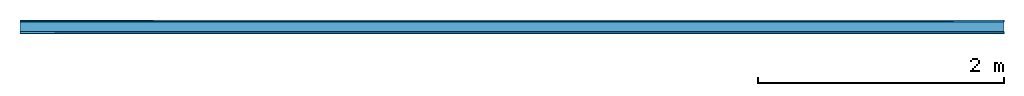
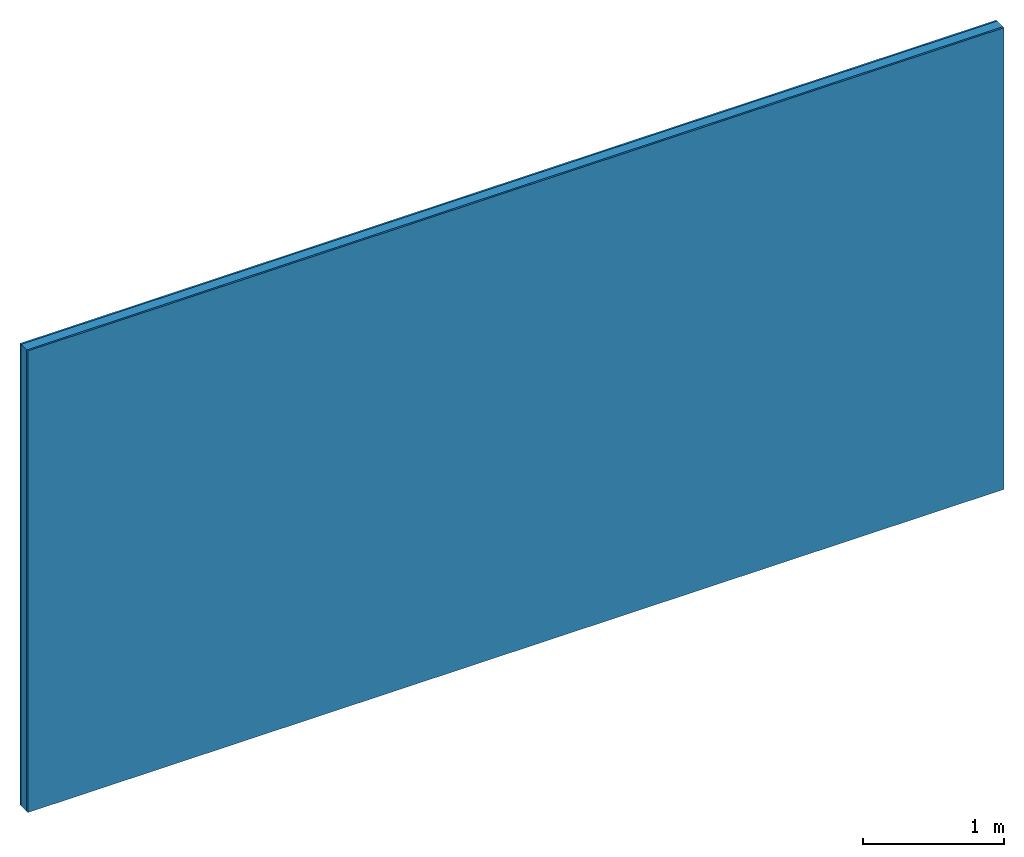
# One storey: 2 plates, 1 member, 1 element without a shape of its own.
"""IFC4 building model written with IfcOpenShell, lengths in metres."""

from ifc_helpers import new_model, si_unit, derived_unit, direction, frame, frame_2d, origin, origin_with_axes, place, context, project, spatial, rectangle, extrude, material, layer, layer_set, type_object, element, aggregate, save


model = new_model("IFC4")

# Units and contexts
plan_context = context("Plan", 3, precision=1e-05, world=origin(), true_north=direction((0.0, 1.0)))
model_context = context("Model", 3, precision=1e-05, world=origin(), true_north=direction((0.0, 1.0)))
ifc_project = project(units=[si_unit("LENGTHUNIT", "METRE"), derived_unit("SOUNDPRESSUREUNIT", [(si_unit("PRESSUREUNIT", "PASCAL", prefix="MICRO"), 0)]), si_unit("ENERGYUNIT", "JOULE", prefix="MEGA"), si_unit("MASSUNIT", "GRAM", prefix="KILO"), derived_unit("THERMALTRANSMITTANCEUNIT", [(si_unit("POWERUNIT", "WATT"), 1), (si_unit("AREAUNIT", "SQUARE_METRE"), -1), (si_unit("THERMODYNAMICTEMPERATUREUNIT", "KELVIN"), -1)]), derived_unit("AREADENSITYUNIT", [(si_unit("MASSUNIT", "GRAM", prefix="KILO"), 1), (si_unit("AREAUNIT", "SQUARE_METRE"), -1)]), derived_unit("USERDEFINED", [(si_unit("ENERGYUNIT", "JOULE", prefix="MEGA"), 1), (si_unit("AREAUNIT", "SQUARE_METRE"), -1)])], contexts=[plan_context, model_context])

# Site, building, storey
site = spatial("IfcSite", under=ifc_project)
building_placement = place(None, origin())
building = spatial("IfcBuilding", under=site, at=building_placement)
storey_placement = place(building_placement, origin())
storey = spatial("IfcBuildingStorey", under=building, at=storey_placement)

# Wall, member, plates
ifc_material_1 = material(Name="Glued joints")
ifc_layer_1 = layer(ifc_material_1, 0.0, Name="Surface")
ifc_material_2 = material(Category="03.007")
ifc_layer_2 = layer(ifc_material_2, 0.015, Name="1st layer")
ifc_material_3 = material(Name="of the art")
ifc_layer_3 = layer(ifc_material_3, 0.0, Name="Bond")
ifc_layer_4 = layer(None, 0.08, Name="Support")
ifc_layer_5 = layer(ifc_material_3, 0.0, Name="Bond")
ifc_layer_6 = layer(ifc_material_2, 0.015, Name="1st layer")
ifc_layer_7 = layer(ifc_material_1, 0.0, Name="Surface")
ifc_layer_set = layer_set([ifc_layer_1, ifc_layer_2, ifc_layer_3, ifc_layer_4, ifc_layer_5, ifc_layer_6, ifc_layer_7])
wall_type = type_object("IfcWallType", Name="C0109", PredefinedType="NOTDEFINED", material=ifc_layer_set)
wall_placement = place(None, frame((0.0, 0.0, 0.0), z_axis=(0.0, -1.0, 0.0), x_axis=(1.0, 0.0, 0.0)))
wall = element("IfcWall", 1, at=wall_placement, inside=storey, type_object=wall_type, material=ifc_layer_set, Name="Wall #1")
ifc_material_4 = material()
member_placement = place(wall_placement, origin())
member = element("IfcMember", 2, at=member_placement, material=ifc_material_4, Name="Support", context=plan_context, shape_type="SweptSolid", body=[
    extrude(rectangle(XDim=1.0, YDim=0.08, at=frame_2d((0.5, 0.04), x_axis=(1.0, 0.0))), frame((0.0, 4.0, 0.015), z_axis=(0.0, -1.0, 0.0), x_axis=(1.0, 0.0, 0.0)), (0.0, 0.0, 1.0), 4.0),
    extrude(rectangle(XDim=1.0, YDim=0.08, at=frame_2d((0.5, 0.04), x_axis=(1.0, 0.0))), frame((1.0, 4.0, 0.015), z_axis=(0.0, -1.0, 0.0), x_axis=(1.0, 0.0, 0.0)), (0.0, 0.0, 1.0), 4.0),
    extrude(rectangle(XDim=1.0, YDim=0.08, at=frame_2d((0.5, 0.04), x_axis=(1.0, 0.0))), frame((2.0, 4.0, 0.015), z_axis=(0.0, -1.0, 0.0), x_axis=(1.0, 0.0, 0.0)), (0.0, 0.0, 1.0), 4.0),
    extrude(rectangle(XDim=1.0, YDim=0.08, at=frame_2d((0.5, 0.04), x_axis=(1.0, 0.0))), frame((3.0, 4.0, 0.015), z_axis=(0.0, -1.0, 0.0), x_axis=(1.0, 0.0, 0.0)), (0.0, 0.0, 1.0), 4.0),
    extrude(rectangle(XDim=1.0, YDim=0.08, at=frame_2d((0.5, 0.04), x_axis=(1.0, 0.0))), frame((4.0, 4.0, 0.015), z_axis=(0.0, -1.0, 0.0), x_axis=(1.0, 0.0, 0.0)), (0.0, 0.0, 1.0), 4.0),
    extrude(rectangle(XDim=1.0, YDim=0.08, at=frame_2d((0.5, 0.04), x_axis=(1.0, 0.0))), frame((5.0, 4.0, 0.015), z_axis=(0.0, -1.0, 0.0), x_axis=(1.0, 0.0, 0.0)), (0.0, 0.0, 1.0), 4.0),
    extrude(rectangle(XDim=1.0, YDim=0.08, at=frame_2d((0.5, 0.04), x_axis=(1.0, 0.0))), frame((6.0, 4.0, 0.015), z_axis=(0.0, -1.0, 0.0), x_axis=(1.0, 0.0, 0.0)), (0.0, 0.0, 1.0), 4.0),
    extrude(rectangle(XDim=1.0, YDim=0.08, at=frame_2d((0.5, 0.04), x_axis=(1.0, 0.0))), frame((7.0, 4.0, 0.015), z_axis=(0.0, -1.0, 0.0), x_axis=(1.0, 0.0, 0.0)), (0.0, 0.0, 1.0), 4.0),
])
plate_1_placement = place(wall_placement, origin())
plate_1 = element("IfcPlate", 3, at=plate_1_placement, material=ifc_material_2, Name="1st layer", context=plan_context, shape_type="SweptSolid", body=[
    extrude(rectangle(XDim=8.0, YDim=4.0, at=frame_2d((4.0, 2.0), x_axis=(1.0, 0.0))), origin_with_axes(), (0.0, 0.0, 1.0), 0.015),
])
plate_2_placement = place(wall_placement, origin())
plate_2 = element("IfcPlate", 4, at=plate_2_placement, material=ifc_material_2, Name="1st layer", context=plan_context, shape_type="SweptSolid", body=[
    extrude(rectangle(XDim=8.0, YDim=4.0, at=frame_2d((4.0, 2.0), x_axis=(1.0, 0.0))), frame((0.0, 0.0, 0.095), z_axis=(0.0, 0.0, 1.0), x_axis=(1.0, 0.0, 0.0)), (0.0, 0.0, 1.0), 0.015),
])
aggregate(wall, [plate_1, member, plate_2])

save(model, "model.ifc")
